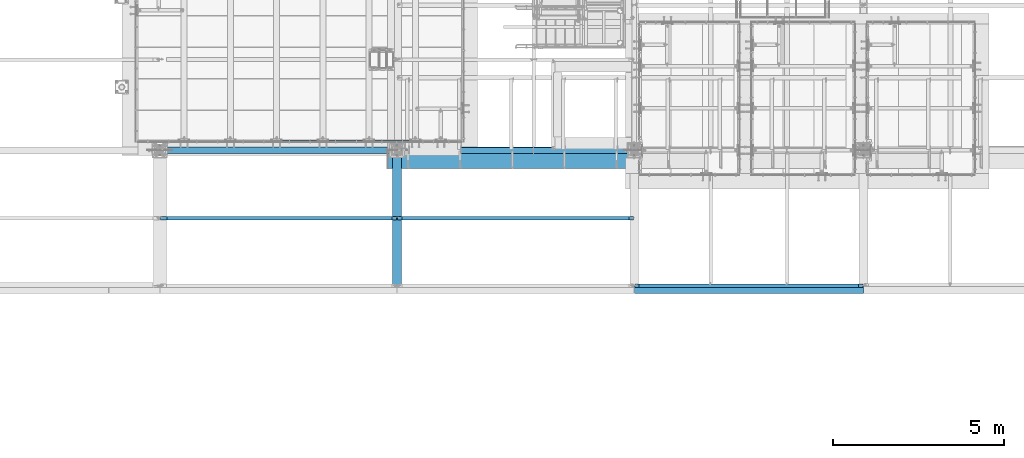
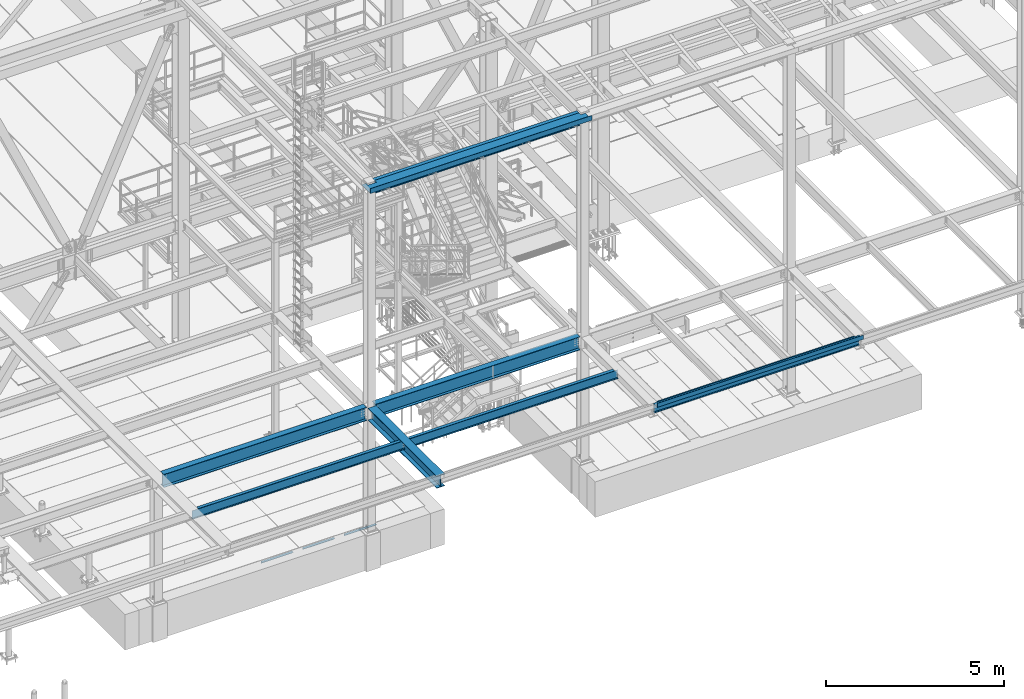
# One storey, part 1750 of 3843: 12 beams, 10 elements without a shape of their own.
"""IFC2X3 building model written with IfcOpenShell, lengths in millimetres."""

from ifc_helpers import new_model, si_unit, frame, origin_with_axes, place, context, subcontext, project, spatial, faceted_brep, material, type_object, element, aggregate, save


model = new_model("IFC2X3")

# Units and contexts
model_context = context("Model", 3, precision=1e-05, world=origin_with_axes())
body_context = subcontext(model_context, "Body", "Model", "MODEL_VIEW")
ifc_project = project(units=[si_unit("LENGTHUNIT", "METRE", prefix="MILLI"), si_unit("AREAUNIT", "SQUARE_METRE"), si_unit("VOLUMEUNIT", "CUBIC_METRE"), si_unit("MASSUNIT", "GRAM", prefix="KILO"), si_unit("TIMEUNIT", "SECOND"), si_unit("PLANEANGLEUNIT", "RADIAN"), si_unit("SOLIDANGLEUNIT", "STERADIAN"), si_unit("THERMODYNAMICTEMPERATUREUNIT", "DEGREE_CELSIUS"), si_unit("LUMINOUSINTENSITYUNIT", "LUMEN")], contexts=[model_context])

# Site, building, storey
site_placement = place(None, origin_with_axes())
site = spatial("IfcSite", under=ifc_project, at=site_placement, CompositionType="ELEMENT")
building_placement = place(site_placement, origin_with_axes())
building = spatial("IfcBuilding", under=site, at=building_placement, Name="Undefined", CompositionType="ELEMENT")
storey_placement = place(building_placement, origin_with_axes())
storey = spatial("IfcBuildingStorey", under=building, at=storey_placement, Name="Undefined", CompositionType="ELEMENT", Elevation=0.0)

# Assembly, beam
assembly_1_placement = place(storey_placement, origin_with_axes())
assembly_1 = element("IfcElementAssembly", 1, at=assembly_1_placement, inside=storey, Name="ANGLE", AssemblyPlace="NOTDEFINED", PredefinedType="RIGID_FRAME")
ifc_material_1 = material(Name="STEEL/A36")
beam_type_1 = type_object("IfcBeamType", Name="L3X3X1/4", PredefinedType="NOTDEFINED")
beam_1_placement = place(assembly_1_placement, frame((49368.0932658982, 15265.4000055596, 30365.7000030518), z_axis=(0.0, 0.0, -1.0), x_axis=(-1.0, 0.0, 0.0)))
beam_1 = element("IfcBeam", 2, at=beam_1_placement, type_object=beam_type_1, material=ifc_material_1, Name="ANGLE", ObjectType="L3X3X1/4", context=body_context, shape_type="Brep", body=[
    faceted_brep([(0.0, 38.0999999999985, -38.0999999999985), (0.0, 38.0999999999985, 38.0999999999985), (1022.33317453146, 38.1000000000004, 38.0999999999985), (1022.33317453146, 38.1000000000004, -38.0999999999985), (0.0, 31.75, 38.0999999999985), (1022.33317453146, 31.75, 38.0999999999985), (0.0, 31.75, -31.75), (1022.33317453146, 31.75, -31.75), (0.0, -38.0999999999985, -31.75), (1022.33317453146, -38.1000000000004, -31.75), (0.0, -38.0999999999985, -38.0999999999985), (1022.33317453146, -38.1000000000004, -38.0999999999985)], [[[0, 1, 2, 3]], [[1, 4, 5, 2]], [[4, 6, 7, 5]], [[6, 8, 9, 7]], [[8, 10, 11, 9]], [[10, 0, 3, 11]], [[5, 7, 9, 11, 3, 2]], [[10, 8, 6, 4, 1, 0]]]),
])
aggregate(assembly_1, [beam_1])

assembly_2_placement = place(storey_placement, origin_with_axes())
assembly_2 = element("IfcElementAssembly", 3, at=assembly_2_placement, inside=storey, Name="ANGLE", AssemblyPlace="NOTDEFINED", PredefinedType="RIGID_FRAME")
beam_2_placement = place(assembly_2_placement, frame((48015.5432658982, 15265.4000976563, 30365.7000030518), z_axis=(0.0, 0.0, -1.0), x_axis=(-1.0, 0.0, 0.0)))
beam_2 = element("IfcBeam", 4, at=beam_2_placement, type_object=beam_type_1, material=ifc_material_1, Name="ANGLE", ObjectType="L3X3X1/4", context=body_context, shape_type="Brep", body=[
    faceted_brep([(0.0, 38.0999999999985, -38.0999999999985), (0.0, 38.0999999999985, 38.0999999999985), (1022.33317453146, 38.1000000000004, 38.0999999999985), (1022.33317453146, 38.1000000000004, -38.0999999999985), (0.0, 31.75, 38.0999999999985), (1022.33317453146, 31.75, 38.0999999999985), (0.0, 31.75, -31.75), (1022.33317453146, 31.75, -31.75), (0.0, -38.0999999999985, -31.75), (1022.33317453146, -38.1000000000004, -31.75), (0.0, -38.0999999999985, -38.0999999999985), (1022.33317453146, -38.1000000000004, -38.0999999999985)], [[[0, 1, 2, 3]], [[1, 4, 5, 2]], [[4, 6, 7, 5]], [[6, 8, 9, 7]], [[8, 10, 11, 9]], [[10, 0, 3, 11]], [[5, 7, 9, 11, 3, 2]], [[10, 8, 6, 4, 1, 0]]]),
])
aggregate(assembly_2, [beam_2])

assembly_3_placement = place(storey_placement, origin_with_axes())
assembly_3 = element("IfcElementAssembly", 5, at=assembly_3_placement, inside=storey, Name="ANGLE", AssemblyPlace="NOTDEFINED", PredefinedType="RIGID_FRAME")
beam_3_placement = place(assembly_3_placement, frame((46662.9932658982, 15265.4000976563, 30365.7000030518), z_axis=(0.0, 0.0, -1.0), x_axis=(-1.0, 0.0, 0.0)))
beam_3 = element("IfcBeam", 6, at=beam_3_placement, type_object=beam_type_1, material=ifc_material_1, Name="ANGLE", ObjectType="L3X3X1/4", context=body_context, shape_type="Brep", body=[
    faceted_brep([(0.0, 38.0999999999985, -38.0999999999985), (0.0, 38.0999999999985, 38.0999999999985), (1022.33317453146, 38.1000000000004, 38.0999999999985), (1022.33317453146, 38.1000000000004, -38.0999999999985), (0.0, 31.75, 38.0999999999985), (1022.33317453146, 31.75, 38.0999999999985), (0.0, 31.75, -31.75), (1022.33317453146, 31.75, -31.75), (0.0, -38.0999999999985, -31.75), (1022.33317453146, -38.1000000000004, -31.75), (0.0, -38.0999999999985, -38.0999999999985), (1022.33317453146, -38.1000000000004, -38.0999999999985)], [[[0, 1, 2, 3]], [[1, 4, 5, 2]], [[4, 6, 7, 5]], [[6, 8, 9, 7]], [[8, 10, 11, 9]], [[10, 0, 3, 11]], [[5, 7, 9, 11, 3, 2]], [[10, 8, 6, 4, 1, 0]]]),
])
aggregate(assembly_3, [beam_3])

assembly_4_placement = place(storey_placement, origin_with_axes())
assembly_4 = element("IfcElementAssembly", 7, at=assembly_4_placement, inside=storey, Name="BEAM", AssemblyPlace="NOTDEFINED", PredefinedType="RIGID_FRAME")
ifc_material_2 = material(Name="STEEL/A992")
beam_type_2 = type_object("IfcBeamType", Name="W12X19", PredefinedType="NOTDEFINED")
beam_4_placement = place(assembly_4_placement, frame((48996.6, 13017.5, 34656.7125), z_axis=(0.0, 0.0, 1.0), x_axis=(1.0, 0.0, 0.0)))
beam_4 = element("IfcBeam", 8, at=beam_4_placement, type_object=beam_type_2, material=ifc_material_2, Name="BEAM", ObjectType="W12X19", context=body_context, shape_type="Brep", body=[
    faceted_brep([(6788.94375000001, -50.7999999999993, 153.987500000003), (6788.94375000001, -50.7999999999993, 144.462500000001), (6788.94375000001, -3.17499999999927, 144.462500000001), (6788.94375000001, -3.17499999999927, 134.937499809275), (6788.94375000001, 3.17499999999927, 134.937499809275), (6788.94375000001, 3.17499999999927, 144.462500000001), (6788.94375000001, 50.7999999999993, 144.462500000001), (6788.94375000001, 50.7999999999993, 153.987500000003), (6789.9104799226, -3.17499999999927, 130.077420291229), (6789.9104799226, 3.17499999999927, 130.077420291229), (6792.66349382307, -3.17499999999927, 125.957243823075), (6792.66349382307, 3.17499999999927, 125.957243823075), (6796.78367029122, -3.17499999999927, 123.204229922601), (6796.78367029122, 3.17499999999927, 123.204229922601), (6801.64374980927, -3.17499999999927, 122.23750000001), (6801.64374980927, 3.17499999999927, 122.23750000001), (6915.94375000001, -3.17499999999927, 122.23750000001), (6915.94375000001, 3.17499999999927, 122.23750000001), (145.256250000006, -50.7999999999993, 153.987500000003), (145.256250000006, 50.7999999999993, 153.987500000003), (145.256250000006, 50.7999999999993, 144.462500000001), (145.256250000006, 3.17499999999927, 144.462500000001), (145.256250000006, 3.17499999999927, 134.937499809275), (145.256250000006, -3.17499999999927, 134.937499809275), (145.256250000006, -3.17499999999927, 144.462500000001), (145.256250000006, -50.7999999999993, 144.462500000001), (144.289520077415, 3.17499999999927, 130.077420291229), (144.289520077415, -3.17499999999927, 130.077420291229), (141.536506176941, 3.17499999999927, 125.957243823075), (141.536506176941, -3.17499999999927, 125.957243823075), (137.416329708787, 3.17499999999927, 123.204229922601), (137.416329708787, -3.17499999999927, 123.204229922601), (132.556250190741, 3.17499999999927, 122.23750000001), (132.556250190741, -3.17499999999927, 122.23750000001), (18.2562500000058, 3.17499999999927, 122.23750000001), (18.2562500000058, -3.17499999999927, 122.23750000001), (18.2562500000058, 3.17499999999927, 115.887499999997), (18.2562500000058, 3.17499999999927, -114.712500000001), (18.2562500000058, 3.17499999999927, -144.462500000001), (18.2562500000058, 50.7999999999993, -144.462500000001), (18.2562500000058, 50.7999999999993, -153.987500000003), (18.2562500000058, -50.7999999999993, -153.987500000003), (18.2562500000058, -50.7999999999993, -144.462500000001), (18.2562500000058, -3.17499999999927, -144.462500000001), (6915.94375000001, 3.17499999999927, -144.462500000001), (6915.94375000001, 50.7999999999993, -144.462500000001), (6915.94375000001, 50.7999999999993, -153.987500000003), (6915.94375000001, -50.7999999999993, -153.987500000003), (6915.94375000001, -50.7999999999993, -144.462500000001), (6915.94375000001, -3.17499999999927, -144.462500000001), (6915.94375000001, 3.17499999999927, 115.887499999997), (6915.94375000001, 3.17499999999927, -114.712500000001)], [[[0, 1, 2, 3, 4, 5, 6, 7]], [[8, 9, 4, 3]], [[10, 11, 9, 8]], [[12, 13, 11, 10]], [[14, 15, 13, 12]], [[16, 17, 15, 14]], [[18, 19, 20, 21, 22, 23, 24, 25]], [[23, 22, 26, 27]], [[27, 26, 28, 29]], [[29, 28, 30, 31]], [[31, 30, 32, 33]], [[33, 32, 34, 35]], [[36, 37, 38, 39, 40, 41, 42, 43, 35, 34]], [[39, 38, 44, 45]], [[40, 39, 45, 46]], [[41, 40, 46, 47]], [[42, 41, 47, 48]], [[43, 42, 48, 49]], [[12, 10, 8, 3, 2, 24, 23, 27, 29, 31, 33, 35, 43, 49, 16, 14]], [[25, 24, 2, 1]], [[18, 25, 1, 0]], [[19, 18, 0, 7]], [[20, 19, 7, 6]], [[21, 20, 6, 5]], [[50, 51, 44, 38, 37, 36, 34, 32, 30, 28, 26, 22, 21, 5, 4, 9, 11, 13, 15, 17]], [[49, 48, 47, 46, 45, 44, 51, 50, 17, 16]]]),
])
aggregate(assembly_4, [beam_4])

assembly_5_placement = place(storey_placement, origin_with_axes())
assembly_5 = element("IfcElementAssembly", 9, at=assembly_5_placement, inside=storey, Name="BEAM", AssemblyPlace="NOTDEFINED", PredefinedType="RIGID_FRAME")
beam_5_placement = place(assembly_5_placement, frame((42062.4, 13017.5, 34656.7125), z_axis=(0.0, 0.0, 1.0), x_axis=(1.0, 0.0, 0.0)))
beam_5 = element("IfcBeam", 10, at=beam_5_placement, type_object=beam_type_2, material=ifc_material_2, Name="BEAM", ObjectType="W12X19", context=body_context, shape_type="Brep", body=[
    faceted_brep([(6788.94375000001, -50.7999999999993, 153.987500000003), (6788.94375000001, -50.7999999999993, 144.462500000001), (6788.94375000001, -3.17499999999927, 144.462500000001), (6788.94375000001, -3.17499999999927, 134.937499809275), (6788.94375000001, 3.17499999999927, 134.937499809275), (6788.94375000001, 3.17499999999927, 144.462500000001), (6788.94375000001, 50.7999999999993, 144.462500000001), (6788.94375000001, 50.7999999999993, 153.987500000003), (6789.9104799226, -3.17499999999927, 130.077420291229), (6789.9104799226, 3.17499999999927, 130.077420291229), (6792.66349382307, -3.17499999999927, 125.957243823075), (6792.66349382307, 3.17499999999927, 125.957243823075), (6796.78367029122, -3.17499999999927, 123.204229922601), (6796.78367029122, 3.17499999999927, 123.204229922601), (6801.64374980927, -3.17499999999927, 122.23750000001), (6801.64374980927, 3.17499999999927, 122.23750000001), (6915.94375000001, -3.17499999999927, 122.23750000001), (6915.94375000001, 3.17499999999927, 122.23750000001), (203.199999999997, -50.7999999999993, 153.987500000003), (203.199999999997, 50.7999999999993, 153.987500000003), (203.199999999997, 50.7999999999993, 144.462500000001), (203.199999999997, 3.17499999999927, 144.462500000001), (203.199999999997, 3.17499999999927, 122.237499809249), (203.199999999997, -3.17499999999927, 122.237499809249), (203.199999999997, -3.17499999999927, 144.462500000001), (203.199999999997, -50.7999999999993, 144.462500000001), (202.233270077406, 3.17499999999927, 117.377420291203), (202.233270077406, -3.17499999999927, 117.377420291203), (199.480256176932, 3.17499999999927, 113.257243823049), (199.480256176932, -3.17499999999927, 113.257243823049), (195.360079708778, 3.17499999999927, 110.504229922575), (195.360079708778, -3.17499999999927, 110.504229922575), (190.500000190732, 3.17499999999927, 109.537499999984), (190.500000190732, -3.17499999999927, 109.537499999984), (19.0499999999956, 3.17499999999927, 109.537499999984), (19.0499999999956, -3.17499999999927, 109.537499999984), (19.0499999999956, 3.17499999999927, 103.1875), (19.0499999999956, 3.17499999999927, -127.412499999999), (19.0499999999956, 3.17499999999927, -144.462500000001), (19.0499999999956, 50.7999999999993, -144.462500000001), (19.0499999999956, 50.7999999999993, -153.987500000003), (19.0499999999956, -50.7999999999993, -153.987500000003), (19.0499999999956, -50.7999999999993, -144.462500000001), (19.0499999999956, -3.17499999999927, -144.462500000001), (6915.94375000001, 3.17499999999927, -144.462500000001), (6915.94375000001, 50.7999999999993, -144.462500000001), (6915.94375000001, 50.7999999999993, -153.987500000003), (6915.94375000001, -50.7999999999993, -153.987500000003), (6915.94375000001, -50.7999999999993, -144.462500000001), (6915.94375000001, -3.17499999999927, -144.462500000001), (6915.94375000001, 3.17499999999927, 115.887499999997), (6915.94375000001, 3.17499999999927, -114.712500000001)], [[[0, 1, 2, 3, 4, 5, 6, 7]], [[8, 9, 4, 3]], [[10, 11, 9, 8]], [[12, 13, 11, 10]], [[14, 15, 13, 12]], [[16, 17, 15, 14]], [[18, 19, 20, 21, 22, 23, 24, 25]], [[23, 22, 26, 27]], [[27, 26, 28, 29]], [[29, 28, 30, 31]], [[31, 30, 32, 33]], [[33, 32, 34, 35]], [[36, 37, 38, 39, 40, 41, 42, 43, 35, 34]], [[39, 38, 44, 45]], [[40, 39, 45, 46]], [[41, 40, 46, 47]], [[42, 41, 47, 48]], [[43, 42, 48, 49]], [[12, 10, 8, 3, 2, 24, 23, 27, 29, 31, 33, 35, 43, 49, 16, 14]], [[25, 24, 2, 1]], [[18, 25, 1, 0]], [[19, 18, 0, 7]], [[20, 19, 7, 6]], [[21, 20, 6, 5]], [[50, 51, 44, 38, 37, 36, 34, 32, 30, 28, 26, 22, 21, 5, 4, 9, 11, 13, 15, 17]], [[49, 48, 47, 46, 45, 44, 51, 50, 17, 16]]]),
])
aggregate(assembly_5, [beam_5])

assembly_6_placement = place(storey_placement, origin_with_axes())
assembly_6 = element("IfcElementAssembly", 11, at=assembly_6_placement, inside=storey, Name="BEAM", AssemblyPlace="NOTDEFINED", PredefinedType="RIGID_FRAME")
beam_6_placement = place(assembly_6_placement, frame((55930.8, 11036.3, 34656.7125), z_axis=(0.0, 0.0, 1.0), x_axis=(1.0, 0.0, 0.0)))
beam_6 = element("IfcBeam", 12, at=beam_6_placement, type_object=beam_type_2, material=ifc_material_2, Name="BEAM", ObjectType="W12X19", context=body_context, shape_type="Brep", body=[
    faceted_brep([(6560.34375, -50.7999999999993, 153.987500000003), (6560.34375, -50.7999999999993, 144.462500000001), (6560.34375, -3.17499999999927, 144.462500000001), (6560.34375, -3.17499999999927, 134.937499809275), (6560.34375, 3.17499999999927, 134.937499809275), (6560.34375, 3.17499999999927, 144.462500000001), (6560.34375, 50.7999999999993, 144.462500000001), (6560.34375, 50.7999999999993, 153.987500000003), (6561.31047992258, -3.17499999999927, 130.077420291229), (6561.31047992258, 3.17499999999927, 130.077420291229), (6564.06349382307, -3.17499999999927, 125.957243823075), (6564.06349382307, 3.17499999999927, 125.957243823075), (6568.18367029122, -3.17499999999927, 123.204229922601), (6568.18367029122, 3.17499999999927, 123.204229922601), (6573.04374980927, -3.17499999999927, 122.23750000001), (6573.04374980927, 3.17499999999927, 122.23750000001), (6687.34375, -3.17499999999927, 122.23750000001), (6687.34375, 3.17499999999927, 122.23750000001), (145.256250000006, -50.7999999999993, 153.987500000003), (145.256250000006, 50.7999999999993, 153.987500000003), (145.256250000006, 50.7999999999993, 144.462500000001), (145.256250000006, 3.17499999999927, 144.462500000001), (145.256250000006, 3.17499999999927, 134.937499809275), (145.256250000006, -3.17499999999927, 134.937499809275), (145.256250000006, -3.17499999999927, 144.462500000001), (145.256250000006, -50.7999999999993, 144.462500000001), (144.289520077415, 3.17499999999927, 130.077420291229), (144.289520077415, -3.17499999999927, 130.077420291229), (141.536506176941, 3.17499999999927, 125.957243823075), (141.536506176941, -3.17499999999927, 125.957243823075), (137.416329708787, 3.17499999999927, 123.204229922601), (137.416329708787, -3.17499999999927, 123.204229922601), (132.556250190741, 3.17499999999927, 122.23750000001), (132.556250190741, -3.17499999999927, 122.23750000001), (18.2562500000058, 3.17499999999927, 122.23750000001), (18.2562500000058, -3.17499999999927, 122.23750000001), (18.2562500000058, 3.17499999999927, 115.887499999997), (18.2562500000058, 3.17499999999927, -114.712500000001), (18.2562500000058, 3.17499999999927, -144.462500000001), (18.2562500000058, 50.7999999999993, -144.462500000001), (18.2562500000058, 50.7999999999993, -153.987500000003), (18.2562500000058, -50.7999999999993, -153.987500000003), (18.2562500000058, -50.7999999999993, -144.462500000001), (18.2562500000058, -3.17499999999927, -144.462500000001), (6687.34375, 3.17499999999927, -144.462500000001), (6687.34375, 50.7999999999993, -144.462500000001), (6687.34375, 50.7999999999993, -153.987500000003), (6687.34375, -50.7999999999993, -153.987500000003), (6687.34375, -50.7999999999993, -144.462500000001), (6687.34375, -3.17499999999927, -144.462500000001), (6687.34375, 3.17499999999927, 115.887499999997), (6687.34375, 3.17499999999927, -114.712500000001)], [[[0, 1, 2, 3, 4, 5, 6, 7]], [[8, 9, 4, 3]], [[10, 11, 9, 8]], [[12, 13, 11, 10]], [[14, 15, 13, 12]], [[16, 17, 15, 14]], [[18, 19, 20, 21, 22, 23, 24, 25]], [[23, 22, 26, 27]], [[27, 26, 28, 29]], [[29, 28, 30, 31]], [[31, 30, 32, 33]], [[33, 32, 34, 35]], [[36, 37, 38, 39, 40, 41, 42, 43, 35, 34]], [[39, 38, 44, 45]], [[40, 39, 45, 46]], [[41, 40, 46, 47]], [[42, 41, 47, 48]], [[43, 42, 48, 49]], [[12, 10, 8, 3, 2, 24, 23, 27, 29, 31, 33, 35, 43, 49, 16, 14]], [[25, 24, 2, 1]], [[18, 25, 1, 0]], [[19, 18, 0, 7]], [[20, 19, 7, 6]], [[21, 20, 6, 5]], [[50, 51, 44, 38, 37, 36, 34, 32, 30, 28, 26, 22, 21, 5, 4, 9, 11, 13, 15, 17]], [[49, 48, 47, 46, 45, 44, 51, 50, 17, 16]]]),
])

assembly_7_placement = place(storey_placement, origin_with_axes())
assembly_7 = element("IfcElementAssembly", 13, at=assembly_7_placement, inside=storey, Name="BEAM", AssemblyPlace="NOTDEFINED", PredefinedType="RIGID_FRAME")
beam_type_3 = type_object("IfcBeamType", PredefinedType="NOTDEFINED")
beam_7_placement = place(assembly_7_placement, frame((52322.4125, 14960.6, 42471.975), z_axis=(-1.0, 0.0, 0.0), x_axis=(0.0, -1.0, 0.0)))
beam_7 = element("IfcBeam", 14, at=beam_7_placement, type_object=beam_type_3, material=ifc_material_1, Name="BENT_PLATE", context=body_context, shape_type="Brep", body=[
    faceted_brep([(104.774999999996, -3.17500000000291, 3184.525), (104.774999999996, 3.17500000000291, 3184.525), (0.0, 3.17500000000291, 3184.52499999999), (0.0, -3.17500000000291, 3184.52499999999), (104.774999999996, -3.17500000000291, 3467.1), (104.774999999996, 3.17500000000291, 3467.1), (0.0, -3.17500000000291, 3467.1), (0.0, 3.17500000000291, 3467.1), (488.949999999997, 3.17500000000291, 3605.213), (0.0, 3.17500000000291, 3605.213), (0.0, -3.17500000000291, 3605.213), (495.299999999996, -3.17500000000291, 3605.213), (495.299999999996, 161.924999999996, 3605.213), (488.949999999997, 161.924999999996, 3605.213), (488.949999999997, 3.17500000000291, -3605.213), (488.949999999997, 161.924999999996, -3605.213), (495.299999999996, 161.924999999996, -3605.213), (495.299999999996, -3.17500000000291, -3605.213), (104.775, -3.17500000000291, -3605.213), (104.775, 3.17500000000291, -3605.213), (104.774999999985, -3.17500000000291, -3467.10000000002), (104.774999999985, 3.17500000000291, -3467.10000000002), (0.0, -3.17500000000291, -3467.10000000001), (0.0, 3.17500000000291, -3467.10000000001)], [[[0, 1, 2, 3]], [[4, 5, 1, 0]], [[6, 7, 5, 4]], [[8, 9, 10, 11, 12, 13]], [[14, 8, 13, 15]], [[12, 16, 15, 13]], [[11, 17, 16, 12]], [[14, 15, 16, 17, 18, 19]], [[20, 21, 19, 18]], [[22, 23, 21, 20]], [[23, 22, 3, 2]], [[9, 8, 14, 19, 21, 23, 2, 1, 5, 7]], [[10, 9, 7, 6]], [[3, 22, 20, 18, 17, 11, 10, 6, 4, 0]]]),
])

# Beam
beam_type_4 = type_object("IfcBeamType", PredefinedType="NOTDEFINED")
beam_8_placement = place(assembly_6_placement, frame((59283.60025, 11036.3, 34813.875), z_axis=(-1.0, 0.0, 0.0), x_axis=(0.0, -1.0, 0.0)))
beam_8 = element("IfcBeam", 15, at=beam_8_placement, type_object=beam_type_4, material=ifc_material_1, Name="BENT_PLATE", context=body_context, shape_type="Brep", body=[
    faceted_brep([(0.0, -3.17500000000291, -3349.625), (0.0, -3.17500000000291, 3349.625), (0.0, 3.17500000000291, 3349.625), (0.0, 3.17500000000291, -3349.625), (222.250006103513, 3.17500000000291, 3349.625), (222.250006103513, 3.17500000000291, -3349.625), (228.600006103512, -3.17500000000291, -3349.625), (228.600006103512, -3.17500000000291, 3349.625), (222.250006103513, 136.524996948239, 3349.625), (222.250006103513, 136.524996948239, -3349.625), (228.600006103512, 136.524996948239, 3349.625), (228.600006103512, 136.524996948239, -3349.625)], [[[0, 1, 2, 3]], [[3, 2, 4, 5]], [[1, 0, 6, 7]], [[5, 4, 8, 9]], [[4, 2, 1, 7, 10, 8]], [[7, 6, 11, 10]], [[6, 0, 3, 5, 9, 11]], [[10, 11, 9, 8]]]),
])

aggregate(assembly_6, [beam_8, beam_6])

beam_type_5 = type_object("IfcBeamType", Name="W16X40", PredefinedType="NOTDEFINED")
beam_9_placement = place(assembly_7_placement, frame((48996.6, 14998.7, 42265.6), z_axis=(0.0, 0.0, 1.0), x_axis=(1.0, 0.0, 0.0)))
beam_9 = element("IfcBeam", 16, at=beam_9_placement, type_object=beam_type_5, material=ifc_material_2, Name="BEAM", ObjectType="W16X40", context=body_context, shape_type="Brep", body=[
    faceted_brep([(141.287499999999, -88.8999999999996, -203.199999999997), (141.287499999999, 88.8999999999996, -203.199999999997), (6792.9125, 88.8999999999996, -203.199999999997), (6792.9125, -88.8999999999996, -203.199999999997), (141.287499999999, -88.8999999999996, -190.5), (141.287499999999, -3.96875, -190.5), (141.287499999999, -3.96875, 190.5), (141.287499999999, -88.8999999999996, 190.5), (141.287499999999, -88.8999999999996, 203.199999999997), (141.287499999999, 88.8999999999996, 203.199999999997), (141.287499999999, 88.8999999999996, 190.5), (141.287499999999, 3.96875, 190.5), (141.287499999999, 3.96875, 165.839999999997), (141.287499999999, 3.96875, -140.439999999995), (141.287499999999, 3.96875, -190.5), (141.287499999999, 88.8999999999996, -190.5), (6792.9125, -88.8999999999996, -190.5), (6792.9125, -3.96875, -190.5), (6792.9125, -3.96875, 190.5), (6792.9125, -88.8999999999996, 190.5), (6792.9125, -88.8999999999996, 203.199999999997), (6792.9125, 88.8999999999996, 203.199999999997), (6792.9125, 88.8999999999996, 190.5), (6792.9125, 3.96875, 190.5), (6792.9125, 3.96875, 165.839999999997), (6792.9125, 3.96875, -153.139999999999), (6792.9125, 3.96875, -190.5), (6792.9125, 88.8999999999996, -190.5)], [[[0, 1, 2, 3]], [[0, 4, 5, 6, 7, 8, 9, 10, 11, 12, 13, 14, 15, 1]], [[5, 4, 16, 17]], [[6, 5, 17, 18]], [[7, 6, 18, 19]], [[8, 7, 19, 20]], [[9, 8, 20, 21]], [[10, 9, 21, 22]], [[11, 10, 22, 23]], [[14, 13, 12, 11, 23, 24, 25, 26]], [[15, 14, 26, 27]], [[1, 15, 27, 2]], [[26, 25, 24, 23, 22, 21, 20, 19, 18, 17, 16, 3, 2, 27]], [[4, 0, 3, 16]]]),
])

aggregate(assembly_7, [beam_7, beam_9])

# Assembly, beam
assembly_8_placement = place(storey_placement, origin_with_axes())
assembly_8 = element("IfcElementAssembly", 17, at=assembly_8_placement, inside=storey, Name="BEAM", AssemblyPlace="NOTDEFINED", PredefinedType="RIGID_FRAME")
beam_type_6 = type_object("IfcBeamType", Name="W18X50", PredefinedType="NOTDEFINED")
beam_10_placement = place(assembly_8_placement, frame((48996.6, 14998.7, 34582.1), z_axis=(0.0, 0.0, 1.0), x_axis=(1.0, 0.0, 0.0)))
beam_10 = element("IfcBeam", 18, at=beam_10_placement, type_object=beam_type_6, material=ifc_material_2, Name="BEAM", ObjectType="W18X50", context=body_context, shape_type="Brep", body=[
    faceted_brep([(141.287500000006, 95.25, -228.599999999999), (141.287500000006, 95.25, -214.3125), (6792.9125, 95.25, -214.3125), (6792.9125, 95.25, -228.599999999999), (141.287500000006, 4.76249999999709, -214.3125), (6792.9125, 4.76250000000073, -214.3125), (141.287500000006, 4.76249999999709, 214.3125), (6792.9125, 4.76250000000073, 214.3125), (141.287500000006, 95.25, 214.3125), (6792.9125, 95.25, 214.3125), (141.287500000006, 95.25, 228.599999999999), (6792.9125, 95.25, 228.599999999999), (141.287500000006, -95.25, 228.599999999999), (6792.9125, -95.25, 228.599999999999), (141.287500000006, -95.25, 214.3125), (6792.9125, -95.25, 214.3125), (141.287500000006, -4.76249999999709, 214.3125), (6792.9125, -4.76250000000073, 214.3125), (141.287500000006, -4.76249999999709, -214.3125), (6792.9125, -4.76250000000073, -214.3125), (141.287500000006, -95.25, -214.3125), (6792.9125, -95.25, -214.3125), (141.287500000006, -95.25, -228.599999999999), (6792.9125, -95.25, -228.599999999999)], [[[0, 1, 2, 3]], [[1, 4, 5, 2]], [[4, 6, 7, 5]], [[6, 8, 9, 7]], [[8, 10, 11, 9]], [[10, 12, 13, 11]], [[12, 14, 15, 13]], [[14, 16, 17, 15]], [[16, 18, 19, 17]], [[18, 20, 21, 19]], [[20, 22, 23, 21]], [[22, 0, 3, 23]], [[5, 7, 9, 11, 13, 15, 17, 19, 21, 23, 3, 2]], [[22, 20, 18, 16, 14, 12, 10, 8, 6, 4, 1, 0]]]),
])
aggregate(assembly_8, [beam_10])

assembly_9_placement = place(storey_placement, origin_with_axes())
assembly_9 = element("IfcElementAssembly", 19, at=assembly_9_placement, inside=storey, Name="BEAM", AssemblyPlace="NOTDEFINED", PredefinedType="RIGID_FRAME")
beam_11_placement = place(assembly_9_placement, frame((42062.4, 14998.7, 34582.1), z_axis=(0.0, 0.0, 1.0), x_axis=(1.0, 0.0, 0.0)))
beam_11 = element("IfcBeam", 20, at=beam_11_placement, type_object=beam_type_6, material=ifc_material_2, Name="BEAM", ObjectType="W18X50", context=body_context, shape_type="Brep", body=[
    faceted_brep([(198.4375, 95.25, -228.599999999999), (198.4375, 95.25, -214.3125), (6792.9125, 95.25, -214.3125), (6792.9125, 95.25, -228.599999999999), (198.4375, 4.76250000000073, -214.3125), (6792.9125, 4.76250000000073, -214.3125), (198.4375, 4.76250000000073, 214.3125), (6792.9125, 4.76250000000073, 214.3125), (198.4375, 95.25, 214.3125), (6792.9125, 95.25, 214.3125), (198.4375, 95.25, 228.599999999999), (6792.9125, 95.25, 228.599999999999), (198.4375, -95.25, 228.599999999999), (6792.9125, -95.25, 228.599999999999), (198.4375, -95.25, 214.3125), (6792.9125, -95.25, 214.3125), (198.4375, -4.76250000000073, 214.3125), (6792.9125, -4.76250000000073, 214.3125), (198.4375, -4.76250000000073, -214.3125), (6792.9125, -4.76250000000073, -214.3125), (198.4375, -95.25, -214.3125), (6792.9125, -95.25, -214.3125), (198.4375, -95.25, -228.599999999999), (6792.9125, -95.25, -228.599999999999)], [[[0, 1, 2, 3]], [[1, 4, 5, 2]], [[4, 6, 7, 5]], [[6, 8, 9, 7]], [[8, 10, 11, 9]], [[10, 12, 13, 11]], [[12, 14, 15, 13]], [[14, 16, 17, 15]], [[16, 18, 19, 17]], [[18, 20, 21, 19]], [[20, 22, 23, 21]], [[22, 0, 3, 23]], [[5, 7, 9, 11, 13, 15, 17, 19, 21, 23, 3, 2]], [[22, 20, 18, 16, 14, 12, 10, 8, 6, 4, 1, 0]]]),
])
aggregate(assembly_9, [beam_11])

assembly_10_placement = place(storey_placement, origin_with_axes())
assembly_10 = element("IfcElementAssembly", 21, at=assembly_10_placement, inside=storey, Name="BEAM", AssemblyPlace="NOTDEFINED", PredefinedType="RIGID_FRAME")
beam_type_7 = type_object("IfcBeamType", Name="W16X77", PredefinedType="NOTDEFINED")
beam_12_placement = place(assembly_10_placement, frame((48996.6, 10985.5, 34601.15), z_axis=(0.0, 0.0, 1.0), x_axis=(0.0, 1.0, 0.0)))
beam_12 = element("IfcBeam", 22, at=beam_12_placement, type_object=beam_type_7, material=ifc_material_2, Name="BEAM", ObjectType="W16X77", context=body_context, shape_type="Brep", body=[
    faceted_brep([(3873.5, -130.175000000003, 190.5), (3873.5, -5.55625000000146, 190.5), (3873.5, 5.55625000000146, 190.5), (3873.5, 130.175000000003, 190.5), (3862.5014184705, 130.175000000003, 209.550000000003), (3862.5014184705, -130.175000000003, 209.550000000003), (0.0, -130.175000000003, -209.550000000003), (0.0, -130.175000000003, -190.5), (0.0, -5.55624999999418, -190.5), (0.0, -5.55624999999418, 190.5), (0.0, -130.175000000003, 190.5), (0.0, -130.175000000003, 209.550000000003), (0.0, 130.175000000003, 209.550000000003), (0.0, 130.175000000003, 190.5), (0.0, 5.55624999999418, 190.5), (0.0, 5.55624999999418, -190.5), (0.0, 130.175000000003, -190.5), (0.0, 130.175000000003, -209.550000000003), (3873.5, -5.55625000000146, 190.102999597169), (3873.5, 5.55625000000146, 190.102999597169), (3848.1, -5.55625000000146, 190.103000000003), (3848.1, 5.55625000000146, 190.103000000003), (3802.18490255129, -5.55625000000146, 182.431780033185), (3802.18490255129, 5.55625000000146, 182.431780033185), (3797.18734235396, -5.55625000000146, 179.936109186565), (3797.18734235396, 5.55625000000146, 179.936109186565), (3794.44848578802, -5.55625000000146, 175.067572896063), (3794.44848578802, 5.55625000000146, 175.067572896063), (3794.91032950347, -5.55625000000146, 169.500645441607), (3794.91032950347, 5.55625000000146, 169.500645441607), (3798.41402793016, -5.55625000000146, 165.15000431236), (3798.41402793016, 5.55625000000146, 165.15000431236), (3803.75452629393, -5.55625000000146, 163.512000000002), (3803.75452629393, 5.55625000000146, 163.512000000002), (3870.325, -5.55625000000146, 163.512000000002), (3870.325, 5.55625000000146, 163.512000000002), (3870.325, -5.55625000000146, -163.512000000002), (3870.325, 5.55625000000146, -163.512000000002), (3804.99752629393, -5.55625000000146, -163.512000000002), (3804.99752629393, 5.55625000000146, -163.512000000002), (3799.65702793016, -5.55625000000146, -165.15000431236), (3799.65702793016, 5.55625000000146, -165.15000431236), (3796.15332950347, -5.55625000000146, -169.500645441607), (3796.15332950347, 5.55625000000146, -169.500645441607), (3795.69148578802, -5.55625000000146, -175.067572896063), (3795.69148578802, 5.55625000000146, -175.067572896063), (3798.43034235396, -5.55625000000146, -179.936109186558), (3798.43034235396, 5.55625000000146, -179.936109186558), (3803.42790255129, -5.55625000000146, -182.431780033185), (3803.42790255129, 5.55625000000146, -182.431780033185), (3849.343, -5.55625000000146, -190.103000000003), (3849.343, 5.55625000000146, -190.103000000003), (3862.27220110753, -5.55625000000146, -190.102999786599), (3862.27220110753, 5.55625000000146, -190.102999786599), (3862.50140246148, 5.55625000000146, -190.5), (3862.50140246148, 130.175000000003, -190.5), (3873.5, 130.175000000003, -209.550000000003), (3873.5, -130.175000000003, -209.550000000003), (3862.50140246148, -130.175000000003, -190.5), (3862.50140246148, -5.55625000000146, -190.5)], [[[0, 1, 2, 3, 4, 5]], [[6, 7, 8, 9, 10, 11, 12, 13, 14, 15, 16, 17]], [[11, 10, 0, 5]], [[12, 11, 5, 4]], [[13, 12, 4, 3]], [[14, 13, 3, 2]], [[18, 19, 2, 1]], [[20, 21, 19, 18]], [[22, 23, 21, 20]], [[24, 25, 23, 22]], [[26, 27, 25, 24]], [[28, 29, 27, 26]], [[30, 31, 29, 28]], [[32, 33, 31, 30]], [[33, 32, 34, 35]], [[34, 36, 37, 35]], [[38, 39, 37, 36]], [[40, 41, 39, 38]], [[42, 43, 41, 40]], [[44, 45, 43, 42]], [[46, 47, 45, 44]], [[48, 49, 47, 46]], [[50, 51, 49, 48]], [[51, 50, 52, 53]], [[15, 14, 2, 19, 21, 23, 25, 27, 29, 31, 33, 35, 37, 39, 41, 43, 45, 47, 49, 51, 53, 54]], [[16, 15, 54, 55]], [[17, 16, 55, 56]], [[6, 17, 56, 57]], [[7, 6, 57, 58]], [[8, 7, 58, 59]], [[57, 56, 55, 54, 53, 52, 59, 58]], [[50, 48, 46, 44, 42, 40, 38, 36, 34, 32, 30, 28, 26, 24, 22, 20, 18, 1, 9, 8, 59, 52]], [[10, 9, 1, 0]]]),
])
aggregate(assembly_10, [beam_12])

save(model, "model.ifc")
